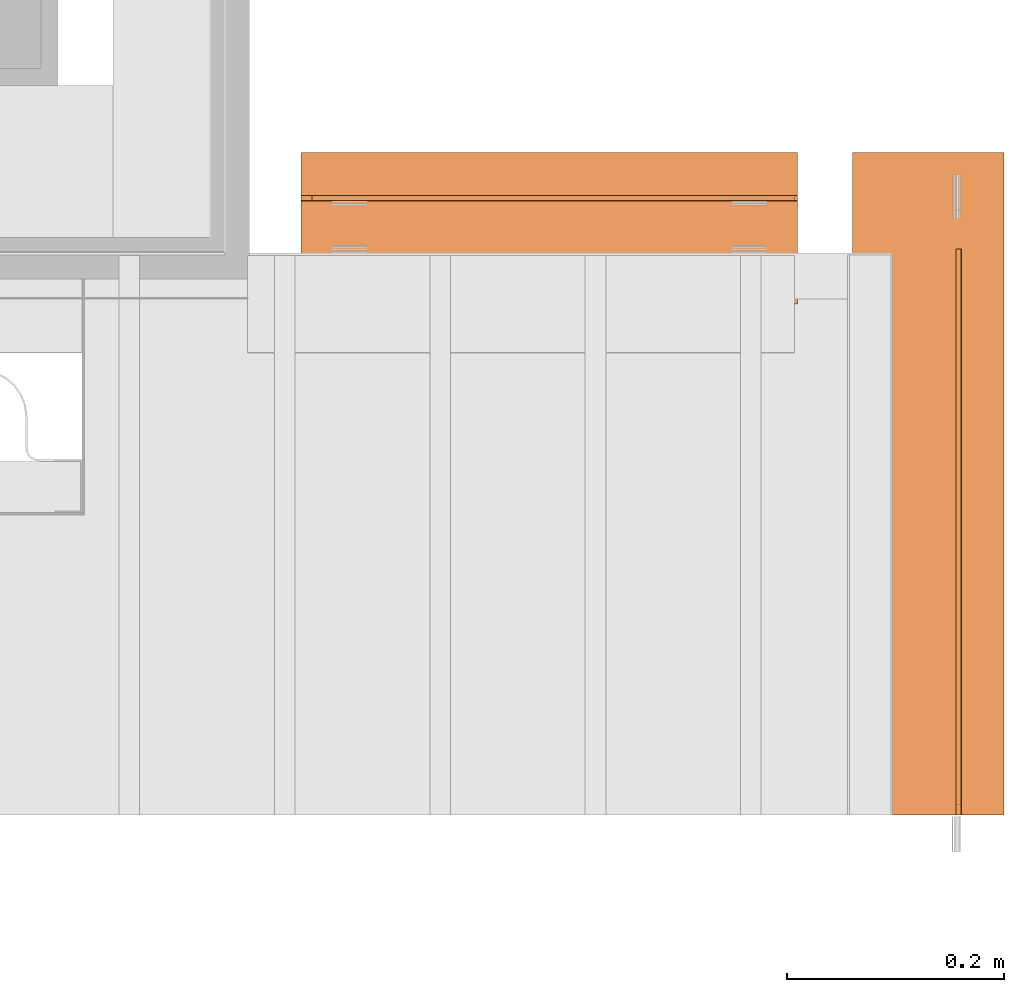
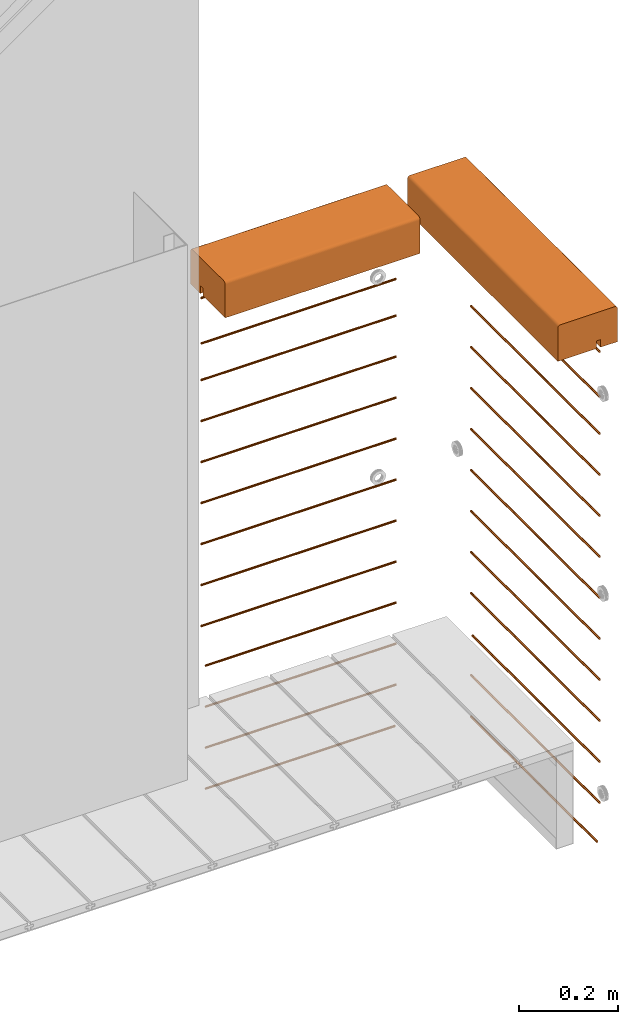
# One storey, part 31 of 33: 28 proxies.
"""IFC4 building model written with IfcOpenShell, lengths in feet."""

from ifc_helpers import new_model, entity, si_unit, converted_unit, derived_unit, direction, frame, frame_2d, origin, origin_2d_with_axis, place, context, subcontext, project, spatial, polyline, circle_curve, parameter, trimmed, segment, composite_curve, circle, outline, extrude, source, transform, mapped, material, type_object, type_shapes, element, save


model = new_model("IFC4")

# Units and contexts
model_context = context("Model", 3, precision=0.0001, world=origin(), true_north=direction((6.12303176911189e-17, 1.0)))
body_context = subcontext(model_context, "Body", "Model", "MODEL_VIEW")
ifc_project = project(units=[converted_unit("LENGTHUNIT", "FOOT", entity("IfcRatioMeasure", 0.3048), si_unit("LENGTHUNIT", "METRE"), dimensions=[1, 0, 0, 0, 0, 0, 0]), converted_unit("AREAUNIT", "SQUARE FOOT", entity("IfcRatioMeasure", 0.09290304), si_unit("AREAUNIT", "SQUARE_METRE"), dimensions=[2, 0, 0, 0, 0, 0, 0]), converted_unit("VOLUMEUNIT", "CUBIC FOOT", entity("IfcRatioMeasure", 0.028316846592), si_unit("VOLUMEUNIT", "CUBIC_METRE"), dimensions=[3, 0, 0, 0, 0, 0, 0]), converted_unit("PLANEANGLEUNIT", "DEGREE", entity("IfcRatioMeasure", 0.0174532925199433), si_unit("PLANEANGLEUNIT", "RADIAN"), dimensions=[0, 0, 0, 0, 0, 0, 0]), si_unit("MASSUNIT", "GRAM", prefix="KILO"), derived_unit("MASSDENSITYUNIT", [(si_unit("MASSUNIT", "GRAM", prefix="KILO"), 1), (si_unit("LENGTHUNIT", "METRE"), -3)]), derived_unit("MOMENTOFINERTIAUNIT", [(si_unit("LENGTHUNIT", "METRE"), 4)]), si_unit("TIMEUNIT", "SECOND"), si_unit("FREQUENCYUNIT", "HERTZ"), si_unit("THERMODYNAMICTEMPERATUREUNIT", "DEGREE_CELSIUS"), derived_unit("THERMALTRANSMITTANCEUNIT", [(si_unit("MASSUNIT", "GRAM", prefix="KILO"), 1), (si_unit("THERMODYNAMICTEMPERATUREUNIT", "KELVIN"), -1), (si_unit("TIMEUNIT", "SECOND"), -3)]), derived_unit("VOLUMETRICFLOWRATEUNIT", [(si_unit("LENGTHUNIT", "METRE"), 3), (si_unit("TIMEUNIT", "SECOND"), -1)]), si_unit("ELECTRICCURRENTUNIT", "AMPERE"), si_unit("ELECTRICVOLTAGEUNIT", "VOLT"), si_unit("POWERUNIT", "WATT"), si_unit("FORCEUNIT", "NEWTON"), si_unit("ILLUMINANCEUNIT", "LUX"), si_unit("LUMINOUSFLUXUNIT", "LUMEN"), si_unit("LUMINOUSINTENSITYUNIT", "CANDELA"), derived_unit("USERDEFINED", [(si_unit("MASSUNIT", "GRAM", prefix="KILO"), -1), (si_unit("LENGTHUNIT", "METRE"), -2), (si_unit("TIMEUNIT", "SECOND"), 3), (si_unit("LUMINOUSFLUXUNIT", "LUMEN"), 1)]), derived_unit("LINEARVELOCITYUNIT", [(si_unit("LENGTHUNIT", "METRE"), 1), (si_unit("TIMEUNIT", "SECOND"), -1)]), si_unit("PRESSUREUNIT", "PASCAL"), derived_unit("USERDEFINED", [(si_unit("LENGTHUNIT", "METRE"), -2), (si_unit("MASSUNIT", "GRAM", prefix="KILO"), 1), (si_unit("TIMEUNIT", "SECOND"), -2)]), derived_unit("LINEARFORCEUNIT", [(si_unit("MASSUNIT", "GRAM", prefix="KILO"), 1), (si_unit("LENGTHUNIT", "METRE"), 1), (si_unit("TIMEUNIT", "SECOND"), -2), (si_unit("LENGTHUNIT", "METRE"), -1)]), derived_unit("PLANARFORCEUNIT", [(si_unit("MASSUNIT", "GRAM", prefix="KILO"), 1), (si_unit("LENGTHUNIT", "METRE"), 1), (si_unit("TIMEUNIT", "SECOND"), -2), (si_unit("LENGTHUNIT", "METRE"), -2)])], contexts=[model_context])

# Site, building, storey
site_placement = place(None, origin())
site = spatial("IfcSite", under=ifc_project, at=site_placement, CompositionType="ELEMENT")
building_placement = place(site_placement, origin())
building = spatial("IfcBuilding", under=site, at=building_placement, CompositionType="ELEMENT")
storey_placement = place(building_placement, frame((0.0, 0.0, 10.0)))
storey = spatial("IfcBuildingStorey", under=building, at=storey_placement, Name="2ND FLOOR", CompositionType="ELEMENT", Elevation=10.0000000000002)

# Proxies
ifc_material_1 = material(Name="CONT. TREATED 4X6 WITH ROUNDED EDGES AT TOP", Category="Materials")
building_element_proxy_type_1 = type_object("IfcBuildingElementProxyType", Name="RAILING:RAILING", PredefinedType="NOTDEFINED", material=ifc_material_1)
shared_shape_1 = source(origin(), body_context, "Body", "SweptSolid", [
    extrude(outline(composite_curve([segment(polyline([(-0.24166666666656, -0.166666666666664), (0.175000000000183, -0.166666666666664)]), True, "CONTINUOUS"), segment(trimmed(circle_curve(frame_2d((0.175000000000183, -0.14583333333333), x_axis=(-1.0, 0.0)), 0.0208333333333333), [parameter(90.0000000000001)], [parameter(180.0)], True, "PARAMETER"), True, "CONTINUOUS"), segment(polyline([(0.19583333333344, -0.14583333333333), (0.195833333333439, 0.125000000000003)]), True, "CONTINUOUS"), segment(polyline([(0.195833333333439, 0.125000000000003), (0.0666666666668329, 0.125000000000002)]), True, "CONTINUOUS"), segment(polyline([(0.0666666666668329, 0.125000000000002), (0.0666666666668331, 0.0625000000000021)]), True, "CONTINUOUS"), segment(polyline([(0.0666666666668331, 0.0625000000000021), (0.0333333333335301, 0.0625000000000019)]), True, "CONTINUOUS"), segment(polyline([(0.0333333333335301, 0.0625000000000019), (0.0333333333335299, 0.125)]), True, "CONTINUOUS"), segment(polyline([(0.0333333333335299, 0.125), (-0.262499999999819, 0.125000000000001)]), True, "CONTINUOUS"), segment(polyline([(-0.262499999999819, 0.125000000000001), (-0.262499999999817, -0.14583333333333)]), True, "CONTINUOUS"), segment(trimmed(circle_curve(frame_2d((-0.24166666666656, -0.14583333333333), x_axis=(1.0, 0.0)), 0.0208333333333333), [parameter(180.0)], [parameter(270.0)], True, "PARAMETER"), True, "CONTINUOUS")], self_intersect=False)), frame((0.267733832794875, 0.0, 0.125000000000005), z_axis=(0.0, 1.0, 0.0), x_axis=(1.0, 0.0, 0.0)), (0.0, 0.0, 1.0), 2.00342499187462),
])
type_shapes(building_element_proxy_type_1, [shared_shape_1])
proxy_1_placement = place(storey_placement, frame((1494.17038887973, 3.0461139299927, 3.88541666666647)))
element("IfcBuildingElementProxy", 1, at=proxy_1_placement, inside=storey, type_object=building_element_proxy_type_1, material=ifc_material_1, Name="RAILING:RAILING", ObjectType="RAILING:RAILING", PredefinedType="NOTDEFINED", context=body_context, shape_type="MappedRepresentation", body=[
    mapped(shared_shape_1, transform((0.0, 0.0, 0.0), scale=1.0)),
])
ifc_material_2 = material(Category="Materials")
building_element_proxy_type_2 = type_object("IfcBuildingElementProxyType", Name="RAILING 1:RAILING 3", PredefinedType="NOTDEFINED", material=ifc_material_2)
shared_shape_2 = source(origin(), body_context, "Body", "SweptSolid", [
    extrude(circle(Radius=0.00833333333333333, at=origin_2d_with_axis()), frame((0.013567166128496, 0.0, 0.0135671661283361), z_axis=(0.0, 1.0, 0.0), x_axis=(1.0, 0.0, 0.0)), (0.0, 0.0, 1.0), 1.71175832520815),
])
type_shapes(building_element_proxy_type_2, [shared_shape_2])
proxy_2_placement = place(storey_placement, frame((1494.48288887973, 3.04611392999268, 3.83851616720477)))
element("IfcBuildingElementProxy", 2, at=proxy_2_placement, inside=storey, type_object=building_element_proxy_type_2, material=ifc_material_2, Name="RAILING 1:RAILING 3", ObjectType="RAILING 1:RAILING 3", PredefinedType="NOTDEFINED", context=body_context, shape_type="MappedRepresentation", body=[
    mapped(shared_shape_2, transform((0.0, 0.0, 0.0), scale=1.0)),
])
building_element_proxy_type_3 = type_object("IfcBuildingElementProxyType", Name="RAILING 3:RAILING 3", PredefinedType="NOTDEFINED", material=ifc_material_2)
shared_shape_3 = source(origin(), body_context, "Body", "SweptSolid", [
    extrude(circle(Radius=0.00833333333333333, at=origin_2d_with_axis()), frame((0.013567166128496, 0.0, 0.0135671661283361), z_axis=(0.0, 1.0, 0.0), x_axis=(1.0, 0.0, 0.0)), (0.0, 0.0, 1.0), 1.71175832520815),
])
type_shapes(building_element_proxy_type_3, [shared_shape_3])
proxy_3_placement = place(storey_placement, frame((1494.48288887973, 3.04611392999268, 3.1718495005381)))
element("IfcBuildingElementProxy", 3, at=proxy_3_placement, inside=storey, type_object=building_element_proxy_type_3, material=ifc_material_2, Name="RAILING 3:RAILING 3", ObjectType="RAILING 3:RAILING 3", PredefinedType="NOTDEFINED", context=body_context, shape_type="MappedRepresentation", body=[
    mapped(shared_shape_3, transform((0.0, 0.0, 0.0), scale=1.0)),
])
building_element_proxy_type_4 = type_object("IfcBuildingElementProxyType", Name="RAILING 4:RAILING 3", PredefinedType="NOTDEFINED", material=ifc_material_2)
shared_shape_4 = source(origin(), body_context, "Body", "SweptSolid", [
    extrude(circle(Radius=0.00833333333333333, at=origin_2d_with_axis()), frame((0.013567166128496, 0.0, 0.0135671661283361), z_axis=(0.0, 1.0, 0.0), x_axis=(1.0, 0.0, 0.0)), (0.0, 0.0, 1.0), 1.71175832520815),
])
type_shapes(building_element_proxy_type_4, [shared_shape_4])
proxy_4_placement = place(storey_placement, frame((1494.48288887973, 3.04611392999268, 2.83851616720477)))
element("IfcBuildingElementProxy", 4, at=proxy_4_placement, inside=storey, type_object=building_element_proxy_type_4, material=ifc_material_2, Name="RAILING 4:RAILING 3", ObjectType="RAILING 4:RAILING 3", PredefinedType="NOTDEFINED", context=body_context, shape_type="MappedRepresentation", body=[
    mapped(shared_shape_4, transform((0.0, 0.0, 0.0), scale=1.0)),
])
building_element_proxy_type_5 = type_object("IfcBuildingElementProxyType", Name="RAILING 5:RAILING 3", PredefinedType="NOTDEFINED", material=ifc_material_2)
shared_shape_5 = source(origin(), body_context, "Body", "SweptSolid", [
    extrude(circle(Radius=0.00833333333333333, at=origin_2d_with_axis()), frame((0.013567166128496, 0.0, 0.0135671661283361), z_axis=(0.0, 1.0, 0.0), x_axis=(1.0, 0.0, 0.0)), (0.0, 0.0, 1.0), 1.71175832520815),
])
type_shapes(building_element_proxy_type_5, [shared_shape_5])
proxy_5_placement = place(storey_placement, frame((1494.48288887973, 3.04611392999268, 2.50518283387144)))
element("IfcBuildingElementProxy", 5, at=proxy_5_placement, inside=storey, type_object=building_element_proxy_type_5, material=ifc_material_2, Name="RAILING 5:RAILING 3", ObjectType="RAILING 5:RAILING 3", PredefinedType="NOTDEFINED", context=body_context, shape_type="MappedRepresentation", body=[
    mapped(shared_shape_5, transform((0.0, 0.0, 0.0), scale=1.0)),
])
building_element_proxy_type_6 = type_object("IfcBuildingElementProxyType", Name="RAILING 6:RAILING 3", PredefinedType="NOTDEFINED", material=ifc_material_2)
shared_shape_6 = source(origin(), body_context, "Body", "SweptSolid", [
    extrude(circle(Radius=0.00833333333333333, at=origin_2d_with_axis()), frame((0.013567166128496, 0.0, 0.0135671661283361), z_axis=(0.0, 1.0, 0.0), x_axis=(1.0, 0.0, 0.0)), (0.0, 0.0, 1.0), 1.71175832520815),
])
type_shapes(building_element_proxy_type_6, [shared_shape_6])
proxy_6_placement = place(storey_placement, frame((1494.48288887973, 3.04611392999268, 2.1718495005381)))
element("IfcBuildingElementProxy", 6, at=proxy_6_placement, inside=storey, type_object=building_element_proxy_type_6, material=ifc_material_2, Name="RAILING 6:RAILING 3", ObjectType="RAILING 6:RAILING 3", PredefinedType="NOTDEFINED", context=body_context, shape_type="MappedRepresentation", body=[
    mapped(shared_shape_6, transform((0.0, 0.0, 0.0), scale=1.0)),
])
building_element_proxy_type_7 = type_object("IfcBuildingElementProxyType", Name="RAILING 7:RAILING 3", PredefinedType="NOTDEFINED", material=ifc_material_2)
shared_shape_7 = source(origin(), body_context, "Body", "SweptSolid", [
    extrude(circle(Radius=0.00833333333333333, at=origin_2d_with_axis()), frame((0.013567166128496, 0.0, 0.0135671661283361), z_axis=(0.0, 1.0, 0.0), x_axis=(1.0, 0.0, 0.0)), (0.0, 0.0, 1.0), 1.71175832520815),
])
type_shapes(building_element_proxy_type_7, [shared_shape_7])
proxy_7_placement = place(storey_placement, frame((1494.48288887973, 3.04611392999268, 1.50518283387144)))
element("IfcBuildingElementProxy", 7, at=proxy_7_placement, inside=storey, type_object=building_element_proxy_type_7, material=ifc_material_2, Name="RAILING 7:RAILING 3", ObjectType="RAILING 7:RAILING 3", PredefinedType="NOTDEFINED", context=body_context, shape_type="MappedRepresentation", body=[
    mapped(shared_shape_7, transform((0.0, 0.0, 0.0), scale=1.0)),
])
building_element_proxy_type_8 = type_object("IfcBuildingElementProxyType", Name="RAILING 8:RAILING 3", PredefinedType="NOTDEFINED", material=ifc_material_2)
shared_shape_8 = source(origin(), body_context, "Body", "SweptSolid", [
    extrude(circle(Radius=0.00833333333333333, at=origin_2d_with_axis()), frame((0.013567166128496, 0.0, 0.0135671661283361), z_axis=(0.0, 1.0, 0.0), x_axis=(1.0, 0.0, 0.0)), (0.0, 0.0, 1.0), 1.71175832520815),
])
type_shapes(building_element_proxy_type_8, [shared_shape_8])
proxy_8_placement = place(storey_placement, frame((1494.48288887973, 3.04611392999268, 1.83851616720477)))
element("IfcBuildingElementProxy", 8, at=proxy_8_placement, inside=storey, type_object=building_element_proxy_type_8, material=ifc_material_2, Name="RAILING 8:RAILING 3", ObjectType="RAILING 8:RAILING 3", PredefinedType="NOTDEFINED", context=body_context, shape_type="MappedRepresentation", body=[
    mapped(shared_shape_8, transform((0.0, 0.0, 0.0), scale=1.0)),
])
building_element_proxy_type_9 = type_object("IfcBuildingElementProxyType", Name="RAILING 9:RAILING 3", PredefinedType="NOTDEFINED", material=ifc_material_2)
shared_shape_9 = source(origin(), body_context, "Body", "SweptSolid", [
    extrude(circle(Radius=0.00833333333333333, at=origin_2d_with_axis()), frame((0.013567166128496, 0.0, 0.0135671661283361), z_axis=(0.0, 1.0, 0.0), x_axis=(1.0, 0.0, 0.0)), (0.0, 0.0, 1.0), 1.71175832520816),
])
type_shapes(building_element_proxy_type_9, [shared_shape_9])
proxy_9_placement = place(storey_placement, frame((1494.48288887973, 3.04611392999268, 1.1718495005381)))
element("IfcBuildingElementProxy", 9, at=proxy_9_placement, inside=storey, type_object=building_element_proxy_type_9, material=ifc_material_2, Name="RAILING 9:RAILING 3", ObjectType="RAILING 9:RAILING 3", PredefinedType="NOTDEFINED", context=body_context, shape_type="MappedRepresentation", body=[
    mapped(shared_shape_9, transform((0.0, 0.0, 0.0), scale=1.0)),
])
building_element_proxy_type_10 = type_object("IfcBuildingElementProxyType", Name="RAILING 10:RAILING 3", PredefinedType="NOTDEFINED", material=ifc_material_2)
shared_shape_10 = source(origin(), body_context, "Body", "SweptSolid", [
    extrude(circle(Radius=0.00833333333333333, at=origin_2d_with_axis()), frame((0.013567166128496, 0.0, 0.0135671661283361), z_axis=(0.0, 1.0, 0.0), x_axis=(1.0, 0.0, 0.0)), (0.0, 0.0, 1.0), 1.71175832520816),
])
type_shapes(building_element_proxy_type_10, [shared_shape_10])
proxy_10_placement = place(storey_placement, frame((1494.48288887973, 3.04611392999268, 0.838516167204769)))
element("IfcBuildingElementProxy", 10, at=proxy_10_placement, inside=storey, type_object=building_element_proxy_type_10, material=ifc_material_2, Name="RAILING 10:RAILING 3", ObjectType="RAILING 10:RAILING 3", PredefinedType="NOTDEFINED", context=body_context, shape_type="MappedRepresentation", body=[
    mapped(shared_shape_10, transform((0.0, 0.0, 0.0), scale=1.0)),
])
building_element_proxy_type_11 = type_object("IfcBuildingElementProxyType", Name="RAILING 11:RAILING 3", PredefinedType="NOTDEFINED", material=ifc_material_2)
shared_shape_11 = source(origin(), body_context, "Body", "SweptSolid", [
    extrude(circle(Radius=0.00833333333333333, at=origin_2d_with_axis()), frame((0.013567166128496, 0.0, 0.0135671661283361), z_axis=(0.0, 1.0, 0.0), x_axis=(1.0, 0.0, 0.0)), (0.0, 0.0, 1.0), 1.69226081335859),
])
type_shapes(building_element_proxy_type_11, [shared_shape_11])
proxy_11_placement = place(storey_placement, frame((1494.48288887973, 3.04611392999273, 0.505182833871435)))
element("IfcBuildingElementProxy", 11, at=proxy_11_placement, inside=storey, type_object=building_element_proxy_type_11, material=ifc_material_2, Name="RAILING 11:RAILING 3", ObjectType="RAILING 11:RAILING 3", PredefinedType="NOTDEFINED", context=body_context, shape_type="MappedRepresentation", body=[
    mapped(shared_shape_11, transform((0.0, 0.0, 0.0), scale=1.0)),
])
building_element_proxy_type_12 = type_object("IfcBuildingElementProxyType", Name="RAILING 12:RAILING 3", PredefinedType="NOTDEFINED", material=ifc_material_2)
shared_shape_12 = source(origin(), body_context, "Body", "SweptSolid", [
    extrude(circle(Radius=0.00833333333333333, at=origin_2d_with_axis()), frame((0.013567166128496, 0.0, 0.0135671661283361), z_axis=(0.0, 1.0, 0.0), x_axis=(1.0, 0.0, 0.0)), (0.0, 0.0, 1.0), 1.71175832520797),
])
type_shapes(building_element_proxy_type_12, [shared_shape_12])
proxy_12_placement = place(storey_placement, frame((1494.48288887973, 3.04611392999268, 0.171849500538103)))
element("IfcBuildingElementProxy", 12, at=proxy_12_placement, inside=storey, type_object=building_element_proxy_type_12, material=ifc_material_2, Name="RAILING 12:RAILING 3", ObjectType="RAILING 12:RAILING 3", PredefinedType="NOTDEFINED", context=body_context, shape_type="MappedRepresentation", body=[
    mapped(shared_shape_12, transform((0.0, 0.0, 0.0), scale=1.0)),
])
building_element_proxy_type_13 = type_object("IfcBuildingElementProxyType", Name="RAILING 20:RAILING 20", PredefinedType="NOTDEFINED", material=ifc_material_2)
shared_shape_13 = source(origin(), body_context, "Body", "SweptSolid", [
    extrude(circle(Radius=0.00833333333333333, at=origin_2d_with_axis()), frame((0.0, 0.0135671661283334, 0.0135671661283325), z_axis=(1.0, 0.0, 0.0), x_axis=(0.0, 1.0, 0.0)), (0.0, 0.0, 1.0), 1.5),
])
type_shapes(building_element_proxy_type_13, [shared_shape_13])
proxy_13_placement = place(storey_placement, frame((1492.50895604586, 4.89847175573906, 3.46965658476597)))
element("IfcBuildingElementProxy", 13, at=proxy_13_placement, inside=storey, type_object=building_element_proxy_type_13, material=ifc_material_2, Name="RAILING 20:RAILING 20", ObjectType="RAILING 20:RAILING 20", PredefinedType="NOTDEFINED", context=body_context, shape_type="MappedRepresentation", body=[
    mapped(shared_shape_13, transform((0.0, 0.0, 0.0), scale=1.0)),
])
building_element_proxy_type_14 = type_object("IfcBuildingElementProxyType", Name="RAILING 21:RAILING 20", PredefinedType="NOTDEFINED", material=ifc_material_2)
shared_shape_14 = source(origin(), body_context, "Body", "SweptSolid", [
    extrude(circle(Radius=0.00833333333333333, at=origin_2d_with_axis()), frame((0.0, 0.0135671661283334, 0.0135671661283325), z_axis=(1.0, 0.0, 0.0), x_axis=(0.0, 1.0, 0.0)), (0.0, 0.0, 1.0), 1.5),
])
type_shapes(building_element_proxy_type_14, [shared_shape_14])
proxy_14_placement = place(storey_placement, frame((1492.50895604586, 4.89847175573906, 3.17184950053811)))
element("IfcBuildingElementProxy", 14, at=proxy_14_placement, inside=storey, type_object=building_element_proxy_type_14, material=ifc_material_2, Name="RAILING 21:RAILING 20", ObjectType="RAILING 21:RAILING 20", PredefinedType="NOTDEFINED", context=body_context, shape_type="MappedRepresentation", body=[
    mapped(shared_shape_14, transform((0.0, 0.0, 0.0), scale=1.0)),
])
building_element_proxy_type_15 = type_object("IfcBuildingElementProxyType", Name="RAILING 22:RAILING 20", PredefinedType="NOTDEFINED", material=ifc_material_2)
shared_shape_15 = source(origin(), body_context, "Body", "SweptSolid", [
    extrude(circle(Radius=0.00833333333333333, at=origin_2d_with_axis()), frame((0.0, 0.0135671661283334, 0.0135671661283325), z_axis=(1.0, 0.0, 0.0), x_axis=(0.0, 1.0, 0.0)), (0.0, 0.0, 1.0), 1.5),
])
type_shapes(building_element_proxy_type_15, [shared_shape_15])
proxy_15_placement = place(storey_placement, frame((1492.50895604586, 4.89847175573906, 2.83851616720477)))
element("IfcBuildingElementProxy", 15, at=proxy_15_placement, inside=storey, type_object=building_element_proxy_type_15, material=ifc_material_2, Name="RAILING 22:RAILING 20", ObjectType="RAILING 22:RAILING 20", PredefinedType="NOTDEFINED", context=body_context, shape_type="MappedRepresentation", body=[
    mapped(shared_shape_15, transform((0.0, 0.0, 0.0), scale=1.0)),
])
building_element_proxy_type_16 = type_object("IfcBuildingElementProxyType", Name="RAILING 23:RAILING 20", PredefinedType="NOTDEFINED", material=ifc_material_2)
shared_shape_16 = source(origin(), body_context, "Body", "SweptSolid", [
    extrude(circle(Radius=0.00833333333333333, at=origin_2d_with_axis()), frame((0.0, 0.0135671661283334, 0.0135671661283325), z_axis=(1.0, 0.0, 0.0), x_axis=(0.0, 1.0, 0.0)), (0.0, 0.0, 1.0), 1.5),
])
type_shapes(building_element_proxy_type_16, [shared_shape_16])
proxy_16_placement = place(storey_placement, frame((1492.50895604586, 4.89847175573906, 2.50518283387144)))
element("IfcBuildingElementProxy", 16, at=proxy_16_placement, inside=storey, type_object=building_element_proxy_type_16, material=ifc_material_2, Name="RAILING 23:RAILING 20", ObjectType="RAILING 23:RAILING 20", PredefinedType="NOTDEFINED", context=body_context, shape_type="MappedRepresentation", body=[
    mapped(shared_shape_16, transform((0.0, 0.0, 0.0), scale=1.0)),
])
building_element_proxy_type_17 = type_object("IfcBuildingElementProxyType", Name="RAILING 24:RAILING 20", PredefinedType="NOTDEFINED", material=ifc_material_2)
shared_shape_17 = source(origin(), body_context, "Body", "SweptSolid", [
    extrude(circle(Radius=0.00833333333333333, at=origin_2d_with_axis()), frame((0.0, 0.0135671661283334, 0.0135671661283325), z_axis=(1.0, 0.0, 0.0), x_axis=(0.0, 1.0, 0.0)), (0.0, 0.0, 1.0), 1.5),
])
type_shapes(building_element_proxy_type_17, [shared_shape_17])
proxy_17_placement = place(storey_placement, frame((1492.50895604586, 4.89847175573906, 2.17184950053811)))
element("IfcBuildingElementProxy", 17, at=proxy_17_placement, inside=storey, type_object=building_element_proxy_type_17, material=ifc_material_2, Name="RAILING 24:RAILING 20", ObjectType="RAILING 24:RAILING 20", PredefinedType="NOTDEFINED", context=body_context, shape_type="MappedRepresentation", body=[
    mapped(shared_shape_17, transform((0.0, 0.0, 0.0), scale=1.0)),
])
building_element_proxy_type_18 = type_object("IfcBuildingElementProxyType", Name="RAILING 25:RAILING 20", PredefinedType="NOTDEFINED", material=ifc_material_2)
shared_shape_18 = source(origin(), body_context, "Body", "SweptSolid", [
    extrude(circle(Radius=0.00833333333333333, at=origin_2d_with_axis()), frame((0.0, 0.0135671661283334, 0.0135671661283325), z_axis=(1.0, 0.0, 0.0), x_axis=(0.0, 1.0, 0.0)), (0.0, 0.0, 1.0), 1.5),
])
type_shapes(building_element_proxy_type_18, [shared_shape_18])
proxy_18_placement = place(storey_placement, frame((1492.50895604586, 4.89847175573906, 1.83851616720477)))
element("IfcBuildingElementProxy", 18, at=proxy_18_placement, inside=storey, type_object=building_element_proxy_type_18, material=ifc_material_2, Name="RAILING 25:RAILING 20", ObjectType="RAILING 25:RAILING 20", PredefinedType="NOTDEFINED", context=body_context, shape_type="MappedRepresentation", body=[
    mapped(shared_shape_18, transform((0.0, 0.0, 0.0), scale=1.0)),
])
building_element_proxy_type_19 = type_object("IfcBuildingElementProxyType", Name="RAILING 26:RAILING 20", PredefinedType="NOTDEFINED", material=ifc_material_2)
shared_shape_19 = source(origin(), body_context, "Body", "SweptSolid", [
    extrude(circle(Radius=0.00833333333333333, at=origin_2d_with_axis()), frame((0.0, 0.0135671661283334, 0.0135671661283325), z_axis=(1.0, 0.0, 0.0), x_axis=(0.0, 1.0, 0.0)), (0.0, 0.0, 1.0), 1.5),
])
type_shapes(building_element_proxy_type_19, [shared_shape_19])
proxy_19_placement = place(storey_placement, frame((1492.50895604586, 4.89847175573906, 1.50518283387144)))
element("IfcBuildingElementProxy", 19, at=proxy_19_placement, inside=storey, type_object=building_element_proxy_type_19, material=ifc_material_2, Name="RAILING 26:RAILING 20", ObjectType="RAILING 26:RAILING 20", PredefinedType="NOTDEFINED", context=body_context, shape_type="MappedRepresentation", body=[
    mapped(shared_shape_19, transform((0.0, 0.0, 0.0), scale=1.0)),
])
building_element_proxy_type_20 = type_object("IfcBuildingElementProxyType", Name="RAILING 27:RAILING 20", PredefinedType="NOTDEFINED", material=ifc_material_2)
shared_shape_20 = source(origin(), body_context, "Body", "SweptSolid", [
    extrude(circle(Radius=0.00833333333333333, at=origin_2d_with_axis()), frame((0.0, 0.0135671661283334, 0.0135671661283325), z_axis=(1.0, 0.0, 0.0), x_axis=(0.0, 1.0, 0.0)), (0.0, 0.0, 1.0), 1.5),
])
type_shapes(building_element_proxy_type_20, [shared_shape_20])
proxy_20_placement = place(storey_placement, frame((1492.50895604586, 4.89847175573906, 1.17184950053811)))
element("IfcBuildingElementProxy", 20, at=proxy_20_placement, inside=storey, type_object=building_element_proxy_type_20, material=ifc_material_2, Name="RAILING 27:RAILING 20", ObjectType="RAILING 27:RAILING 20", PredefinedType="NOTDEFINED", context=body_context, shape_type="MappedRepresentation", body=[
    mapped(shared_shape_20, transform((0.0, 0.0, 0.0), scale=1.0)),
])
building_element_proxy_type_21 = type_object("IfcBuildingElementProxyType", Name="RAILING 28:RAILING 20", PredefinedType="NOTDEFINED", material=ifc_material_2)
shared_shape_21 = source(origin(), body_context, "Body", "SweptSolid", [
    extrude(circle(Radius=0.00833333333333333, at=origin_2d_with_axis()), frame((0.0, 0.0135671661283334, 0.0135671661283325), z_axis=(1.0, 0.0, 0.0), x_axis=(0.0, 1.0, 0.0)), (0.0, 0.0, 1.0), 1.46677557746921),
])
type_shapes(building_element_proxy_type_21, [shared_shape_21])
proxy_21_placement = place(storey_placement, frame((1492.54218046839, 4.89847175573906, 0.838516167204773)))
element("IfcBuildingElementProxy", 21, at=proxy_21_placement, inside=storey, type_object=building_element_proxy_type_21, material=ifc_material_2, Name="RAILING 28:RAILING 20", ObjectType="RAILING 28:RAILING 20", PredefinedType="NOTDEFINED", context=body_context, shape_type="MappedRepresentation", body=[
    mapped(shared_shape_21, transform((0.0, 0.0, 0.0), scale=1.0)),
])
building_element_proxy_type_22 = type_object("IfcBuildingElementProxyType", Name="RAILING 36:RAILING 20", PredefinedType="NOTDEFINED", material=ifc_material_2)
shared_shape_22 = source(origin(), body_context, "Body", "SweptSolid", [
    extrude(circle(Radius=0.00833333333333333, at=origin_2d_with_axis()), frame((0.0, 0.0135671661283334, 0.0135671661283325), z_axis=(1.0, 0.0, 0.0), x_axis=(0.0, 1.0, 0.0)), (0.0, 0.0, 1.0), 1.5),
])
type_shapes(building_element_proxy_type_22, [shared_shape_22])
proxy_22_placement = place(storey_placement, frame((1492.50895604586, 4.89847175573906, 3.83851616720477)))
element("IfcBuildingElementProxy", 22, at=proxy_22_placement, inside=storey, type_object=building_element_proxy_type_22, material=ifc_material_2, Name="RAILING 36:RAILING 20", ObjectType="RAILING 36:RAILING 20", PredefinedType="NOTDEFINED", context=body_context, shape_type="MappedRepresentation", body=[
    mapped(shared_shape_22, transform((0.0, 0.0, 0.0), scale=1.0)),
])
building_element_proxy_type_23 = type_object("IfcBuildingElementProxyType", Name="RAILING 13:RAILING 20", PredefinedType="NOTDEFINED", material=ifc_material_2)
shared_shape_23 = source(origin(), body_context, "Body", "SweptSolid", [
    extrude(circle(Radius=0.00833333333333333, at=origin_2d_with_axis()), frame((0.0, 0.0135671661283334, 0.0135671661283325), z_axis=(1.0, 0.0, 0.0), x_axis=(0.0, 1.0, 0.0)), (0.0, 0.0, 1.0), 1.46677557746921),
])
type_shapes(building_element_proxy_type_23, [shared_shape_23])
proxy_23_placement = place(storey_placement, frame((1492.54218046839, 4.89847175573906, 0.505182833871439)))
element("IfcBuildingElementProxy", 23, at=proxy_23_placement, inside=storey, type_object=building_element_proxy_type_23, material=ifc_material_2, Name="RAILING 13:RAILING 20", ObjectType="RAILING 13:RAILING 20", PredefinedType="NOTDEFINED", context=body_context, shape_type="MappedRepresentation", body=[
    mapped(shared_shape_23, transform((0.0, 0.0, 0.0), scale=1.0)),
])
building_element_proxy_type_24 = type_object("IfcBuildingElementProxyType", Name="RAILING 48:RAILING 20", PredefinedType="NOTDEFINED", material=ifc_material_2)
shared_shape_24 = source(origin(), body_context, "Body", "SweptSolid", [
    extrude(circle(Radius=0.00833333333333333, at=origin_2d_with_axis()), frame((0.0, 0.0135671661283334, 0.0135671661283325), z_axis=(1.0, 0.0, 0.0), x_axis=(0.0, 1.0, 0.0)), (0.0, 0.0, 1.0), 1.46677557746921),
])
type_shapes(building_element_proxy_type_24, [shared_shape_24])
proxy_24_placement = place(storey_placement, frame((1492.54218046839, 4.89847175573906, 0.171849500538107)))
element("IfcBuildingElementProxy", 24, at=proxy_24_placement, inside=storey, type_object=building_element_proxy_type_24, material=ifc_material_2, Name="RAILING 48:RAILING 20", ObjectType="RAILING 48:RAILING 20", PredefinedType="NOTDEFINED", context=body_context, shape_type="MappedRepresentation", body=[
    mapped(shared_shape_24, transform((0.0, 0.0, 0.0), scale=1.0)),
])
building_element_proxy_type_25 = type_object("IfcBuildingElementProxyType", Name="RAILING 60:RAILING 3", PredefinedType="NOTDEFINED", material=ifc_material_2)
shared_shape_25 = source(origin(), body_context, "Body", "SweptSolid", [
    extrude(circle(Radius=0.00833333333333333, at=origin_2d_with_axis()), frame((0.013567166128496, 0.0, 0.0135671661283361), z_axis=(0.0, 1.0, 0.0), x_axis=(1.0, 0.0, 0.0)), (0.0, 0.0, 1.0), 1.7117583252081),
])
type_shapes(building_element_proxy_type_25, [shared_shape_25])
proxy_25_placement = place(storey_placement, frame((1494.48288887973, 3.04611392999268, 3.47255531767878)))
element("IfcBuildingElementProxy", 25, at=proxy_25_placement, inside=storey, type_object=building_element_proxy_type_25, material=ifc_material_2, Name="RAILING 60:RAILING 3", ObjectType="RAILING 60:RAILING 3", PredefinedType="NOTDEFINED", context=body_context, shape_type="MappedRepresentation", body=[
    mapped(shared_shape_25, transform((0.0, 0.0, 0.0), scale=1.0)),
])
building_element_proxy_type_26 = type_object("IfcBuildingElementProxyType", Name="RAILING 61:RAILING 20", PredefinedType="NOTDEFINED", material=ifc_material_2)
shared_shape_26 = source(origin(), body_context, "Body", "SweptSolid", [
    extrude(circle(Radius=0.00833333333333333, at=origin_2d_with_axis()), frame((0.0, 0.0135671661283334, 0.0135671661283325), z_axis=(1.0, 0.0, 0.0), x_axis=(0.0, 1.0, 0.0)), (0.0, 0.0, 1.0), 1.459107468713),
])
type_shapes(building_element_proxy_type_26, [shared_shape_26])
proxy_26_placement = place(storey_placement, frame((1492.54218046839, 4.89847175573906, -0.161483832795229)))
element("IfcBuildingElementProxy", 26, at=proxy_26_placement, inside=storey, type_object=building_element_proxy_type_26, material=ifc_material_2, Name="RAILING 61:RAILING 20", ObjectType="RAILING 61:RAILING 20", PredefinedType="NOTDEFINED", context=body_context, shape_type="MappedRepresentation", body=[
    mapped(shared_shape_26, transform((0.0, 0.0, 0.0), scale=1.0)),
])
building_element_proxy_type_27 = type_object("IfcBuildingElementProxyType", Name="RAILING 62:RAILING 3", PredefinedType="NOTDEFINED", material=ifc_material_2)
shared_shape_27 = source(origin(), body_context, "Body", "SweptSolid", [
    extrude(circle(Radius=0.00833333333333333, at=origin_2d_with_axis()), frame((0.013567166128496, 0.0, 0.0135671661283361), z_axis=(0.0, 1.0, 0.0), x_axis=(1.0, 0.0, 0.0)), (0.0, 0.0, 1.0), 1.67905011872063),
])
type_shapes(building_element_proxy_type_27, [shared_shape_27])
proxy_27_placement = place(storey_placement, frame((1494.48288887973, 3.07882213648387, -0.165389195956603)))
element("IfcBuildingElementProxy", 27, at=proxy_27_placement, inside=storey, type_object=building_element_proxy_type_27, material=ifc_material_2, Name="RAILING 62:RAILING 3", ObjectType="RAILING 62:RAILING 3", PredefinedType="NOTDEFINED", context=body_context, shape_type="MappedRepresentation", body=[
    mapped(shared_shape_27, transform((0.0, 0.0, 0.0), scale=1.0)),
])
building_element_proxy_type_28 = type_object("IfcBuildingElementProxyType", Name="RAILING1:RAILING", PredefinedType="NOTDEFINED", material=ifc_material_1)
shared_shape_28 = source(origin(), body_context, "Body", "SweptSolid", [
    extrude(outline(composite_curve([segment(polyline([(-0.24166666666656, -0.166666666666664), (0.175000000000183, -0.166666666666664)]), True, "CONTINUOUS"), segment(trimmed(circle_curve(frame_2d((0.175000000000183, -0.14583333333333), x_axis=(-1.0, 0.0)), 0.0208333333333333), [parameter(90.0000000000001)], [parameter(180.0)], True, "PARAMETER"), True, "CONTINUOUS"), segment(polyline([(0.19583333333344, -0.14583333333333), (0.195833333333439, 0.125000000000003)]), True, "CONTINUOUS"), segment(polyline([(0.195833333333439, 0.125000000000003), (0.0666666666668329, 0.125000000000002)]), True, "CONTINUOUS"), segment(polyline([(0.0666666666668329, 0.125000000000002), (0.0666666666668331, 0.0625000000000021)]), True, "CONTINUOUS"), segment(polyline([(0.0666666666668331, 0.0625000000000021), (0.0333333333335301, 0.0625000000000019)]), True, "CONTINUOUS"), segment(polyline([(0.0333333333335301, 0.0625000000000019), (0.0333333333335299, 0.125)]), True, "CONTINUOUS"), segment(polyline([(0.0333333333335299, 0.125), (-0.262499999999819, 0.125000000000001)]), True, "CONTINUOUS"), segment(polyline([(-0.262499999999819, 0.125000000000001), (-0.262499999999817, -0.14583333333333)]), True, "CONTINUOUS"), segment(trimmed(circle_curve(frame_2d((-0.24166666666656, -0.14583333333333), x_axis=(1.0, 0.0)), 0.0208333333333333), [parameter(180.0)], [parameter(270.0)], True, "PARAMETER"), True, "CONTINUOUS")], self_intersect=False)), frame((0.267733832794875, 0.0, 0.125000000000004), z_axis=(0.0, 1.0, 0.0), x_axis=(1.0, 0.0, 0.0)), (0.0, 0.0, 1.0), 1.49999999999998),
])
type_shapes(building_element_proxy_type_28, [shared_shape_28])
proxy_28_placement = place(storey_placement, frame((1494.00895604586, 4.58597175573913, 3.88541666666648), z_axis=(0.0, 0.0, 1.0), x_axis=(0.0, 1.0, 0.0)))
element("IfcBuildingElementProxy", 28, at=proxy_28_placement, inside=storey, type_object=building_element_proxy_type_28, material=ifc_material_1, Name="RAILING1:RAILING", ObjectType="RAILING1:RAILING", PredefinedType="NOTDEFINED", context=body_context, shape_type="MappedRepresentation", body=[
    mapped(shared_shape_28, transform((0.0, 0.0, 0.0), scale=1.0)),
])

save(model, "model.ifc")
